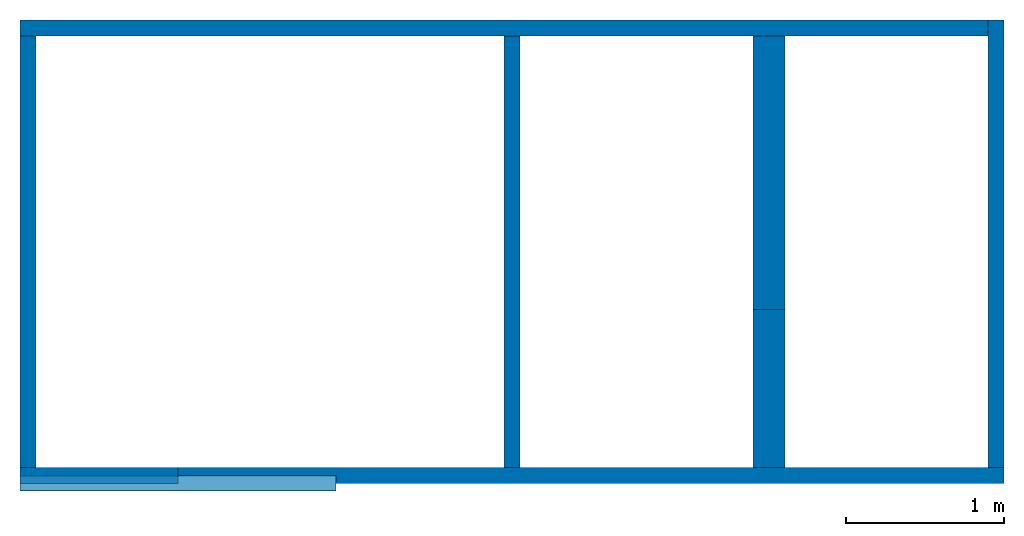
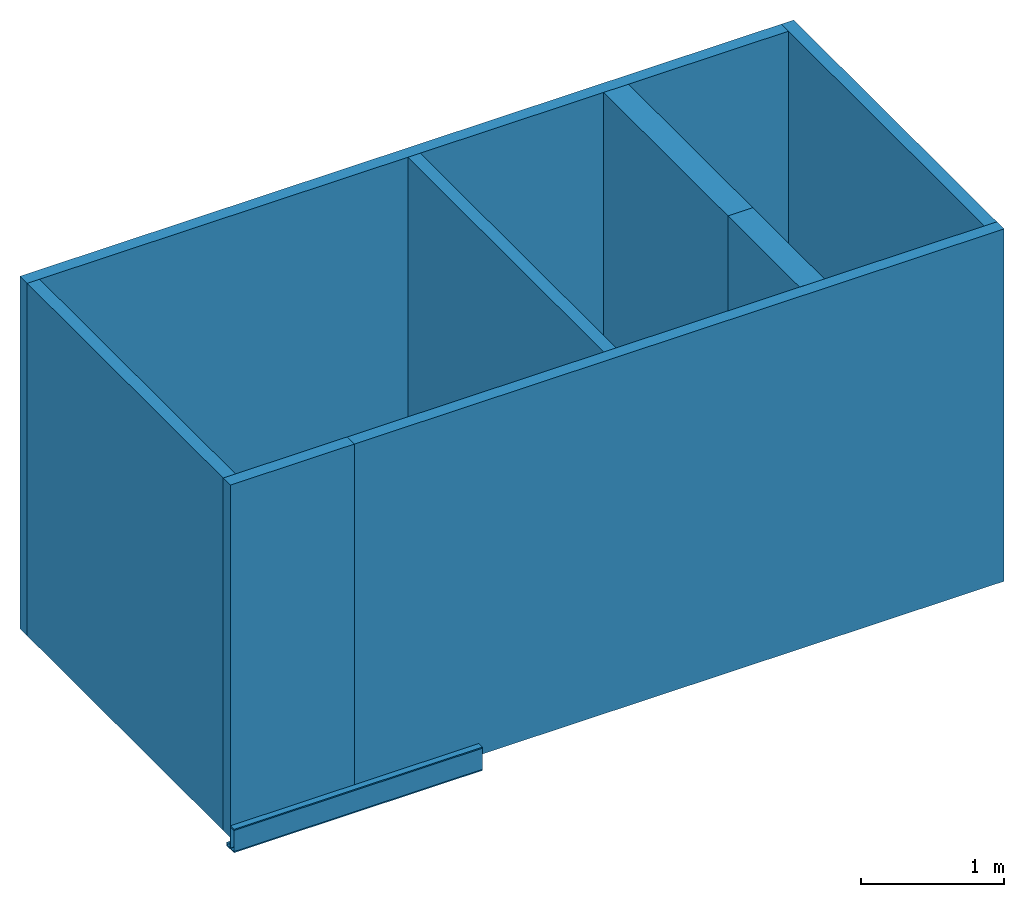
# One storey: 8 walls, 2 beams.
"""IFC4 building model written with IfcOpenShell, lengths in millimetres."""

from ifc_helpers import new_model, entity, si_unit, converted_unit, frame, origin_with_axes, place, context, subcontext, project, spatial, polyline, i_section, c_section, outline, extrude, material, layer, layer_set, layer_usage, material_profile, profile_set, profile_usage, type_object, element, save


model = new_model("IFC4")

# Units and contexts
model_context = context("Model", 3, precision=1e-05)
plan_context = context("Plan", 2, precision=1e-05)
body_context = subcontext(model_context, "Body", "Model", "MODEL_VIEW")
ifc_project = project(units=[si_unit("AREAUNIT", "SQUARE_METRE", prefix="MILLI"), si_unit("VOLUMEUNIT", "CUBIC_METRE", prefix="MILLI"), si_unit("LENGTHUNIT", "METRE", prefix="MILLI"), converted_unit("PLANEANGLEUNIT", "degree", entity("IfcReal", 0.0174532925199433), si_unit("PLANEANGLEUNIT", "RADIAN"), dimensions=[0, 0, 0, 0, 0, 0, 0])], contexts=[model_context, plan_context])

# Site, building, storey
site_placement = place(None, origin_with_axes())
site = spatial("IfcSite", under=ifc_project, at=site_placement)
building_placement = place(site_placement, origin_with_axes())
building = spatial("IfcBuilding", under=site, at=building_placement, Name="Building")
storey_placement = place(building_placement, origin_with_axes())
storey = spatial("IfcBuildingStorey", under=building, at=storey_placement, Name="Storey")

# Beams
ifc_material = material()
ifc_material_profile_1 = material_profile(ifc_material, i_section(OverallWidth=100.0, OverallDepth=200.0, WebThickness=5.0, FlangeThickness=10.0, FilletRadius=5.0))
ifc_profile_set_1 = profile_set([ifc_material_profile_1])
ifc_profile_usage_1 = profile_usage(ifc_profile_set_1)
beam_type_1 = type_object("IfcBeamType", Name="DEMO1", material=ifc_profile_set_1)
beam_1_placement = place(storey_placement, frame((0.0, 0.0, 0.0), z_axis=(1.0, 4.37113882867379e-08, -4.37113882867379e-08), x_axis=(-4.37113882867379e-08, 1.0, 0.0)))
element("IfcBeam", 1, at=beam_1_placement, inside=storey, type_object=beam_type_1, material=ifc_profile_usage_1, Name="Beam", context=body_context, shape_type="SweptSolid", body=[
    extrude(i_section(OverallWidth=100.0, OverallDepth=200.0, WebThickness=5.0, FlangeThickness=10.0, FilletRadius=5.0), None, (0.0, 0.0, 1.0), 2000.0),
])
ifc_material_profile_2 = material_profile(ifc_material, c_section(Depth=200.0, Width=100.0, WallThickness=1.5, Girth=30.0, InternalFilletRadius=5.0))
ifc_profile_set_2 = profile_set([ifc_material_profile_2])
ifc_profile_usage_2 = profile_usage(ifc_profile_set_2)
beam_type_2 = type_object("IfcBeamType", Name="DEMO2", material=ifc_profile_set_2)
beam_2_placement = place(storey_placement, frame((0.0, 0.0, 0.0), z_axis=(1.0, 4.37113882867379e-08, -4.37113882867379e-08), x_axis=(-4.37113882867379e-08, 1.0, 0.0)))
element("IfcBeam", 2, at=beam_2_placement, inside=storey, type_object=beam_type_2, material=ifc_profile_usage_2, Name="Beam", context=body_context, shape_type="SweptSolid", body=[
    extrude(c_section(Depth=200.0, Width=100.0, WallThickness=1.5, Girth=30.0, InternalFilletRadius=5.0), None, (0.0, 0.0, 1.0), 2000.0),
])

# Walls
ifc_layer_1 = layer(ifc_material, 100.0)
ifc_layer_set_1 = layer_set([ifc_layer_1])
ifc_layer_usage_1 = layer_usage(ifc_layer_set_1, "AXIS2", "POSITIVE", 0.0)
wall_type_1 = type_object("IfcWallType", Name="DEMO100", material=ifc_layer_set_1)
wall_1_placement = place(storey_placement, origin_with_axes())
element("IfcWall", 3, at=wall_1_placement, inside=storey, type_object=wall_type_1, material=ifc_layer_usage_1, Name="Wall", context=body_context, shape_type="SweptSolid", body=[
    extrude(outline(polyline([(-50.0000007450581, -500.0), (50.0000007450581, -500.0), (50.0000007450581, 500.0), (-50.0000007450581, 500.0), (-50.0000007450581, -500.0)])), frame((500.0, 50.0000007450581, 0.0), z_axis=(0.0, 0.0, -1.0), x_axis=(0.0, -1.0, 0.0)), (0.0, 0.0, -1.0), 3000.0),
])
ifc_layer_usage_2 = layer_usage(ifc_layer_set_1, "AXIS2", "POSITIVE", 0.0)
wall_2_placement = place(storey_placement, origin_with_axes())
element("IfcWall", 4, at=wall_2_placement, inside=storey, type_object=wall_type_1, material=ifc_layer_usage_2, Name="Wall", context=body_context, shape_type="SweptSolid", body=[
    extrude(outline(polyline([(-50.0000007450581, -3114.86148834229), (50.0000007450581, -3114.86148834229), (50.0000007450581, 3114.86148834229), (-50.0000007450581, 3114.86148834229), (-50.0000007450581, -3114.86148834229)])), frame((3114.86148834229, 50.0000007450581, 0.0), z_axis=(0.0, 0.0, -1.0), x_axis=(0.0, -1.0, 0.0)), (0.0, 0.0, -1.0), 3000.0),
])
ifc_layer_usage_3 = layer_usage(ifc_layer_set_1, "AXIS2", "POSITIVE", 0.0)
wall_3_placement = place(storey_placement, frame((6229.72297668457, 100.000023841858, 0.0), z_axis=(0.0, 0.0, 1.0), x_axis=(-4.37113882867379e-08, 1.0, 0.0)))
element("IfcWall", 5, at=wall_3_placement, inside=storey, type_object=wall_type_1, material=ifc_layer_usage_3, Name="Wall", context=body_context, shape_type="SweptSolid", body=[
    extrude(outline(polyline([(-49.999862909317, -1416.52250289917), (50.0000417232513, -1416.52250289917), (49.9999150633812, 1416.52250289917), (-50.0000864267349, 1416.52250289917), (-49.999862909317, -1416.52250289917)])), frame((1416.52250289917, 49.9999150633812, 0.0), z_axis=(0.0, 0.0, -1.0), x_axis=(0.0, -1.0, 0.0)), (0.0, 0.0, -1.0), 3000.0),
])
ifc_layer_usage_4 = layer_usage(ifc_layer_set_1, "AXIS2", "POSITIVE", 0.0)
wall_4_placement = place(storey_placement, frame((6129.723072052, 2933.04491043091, 0.0), z_axis=(0.0, 0.0, 1.0), x_axis=(-1.0, 1.50995802528087e-07, 0.0)))
element("IfcWall", 6, at=wall_4_placement, inside=storey, type_object=wall_type_1, material=ifc_layer_usage_4, Name="Wall", context=body_context, shape_type="SweptSolid", body=[
    extrude(outline(polyline([(-49.9998703598976, -3064.86129760742), (50.0002726912498, -3064.86129760742), (49.9997958540916, 3064.86129760742), (-50.0002056360245, 3064.86129760742), (-49.9998703598976, -3064.86129760742)])), frame((3064.86129760742, 49.9997958540916, 0.0), z_axis=(0.0, 0.0, -1.0), x_axis=(0.0, -1.0, 0.0)), (0.0, 0.0, -1.0), 3000.0),
])
ifc_layer_usage_5 = layer_usage(ifc_layer_set_1, "AXIS2", "POSITIVE", 0.0)
wall_5_placement = place(storey_placement, frame((0.000476837158203125, 2833.04619789124, 0.0), z_axis=(0.0, 0.0, 1.0), x_axis=(-1.62920684942947e-07, -1.0, 0.0)))
element("IfcWall", 7, at=wall_5_placement, inside=storey, type_object=wall_type_1, material=ifc_layer_usage_5, Name="Wall", context=body_context, shape_type="SweptSolid", body=[
    extrude(outline(polyline([(-50.000011920929, -1366.52302742004), (49.9999895691872, -1366.52302742004), (50.000011920929, 1366.52302742004), (-49.9999895691872, 1366.52302742004), (-50.000011920929, -1366.52302742004)])), frame((1366.52302742004, 50.000011920929, 0.0), z_axis=(0.0, 0.0, -1.0), x_axis=(0.0, -1.0, 0.0)), (0.0, 0.0, -1.0), 3000.0),
])
ifc_layer_usage_6 = layer_usage(ifc_layer_set_1, "AXIS2", "POSITIVE", 0.0)
wall_6_placement = place(storey_placement, frame((3064.86177444458, 2833.0454826355, 0.0), z_axis=(0.0, 0.0, 1.0), x_axis=(-1.62920684942947e-07, -1.0, 0.0)))
element("IfcWall", 8, at=wall_6_placement, inside=storey, type_object=wall_type_1, material=ifc_layer_usage_6, Name="Wall", context=body_context, shape_type="SweptSolid", body=[
    extrude(outline(polyline([(-49.9999821186066, -1366.52266979218), (50.0001609325409, -1366.52266979218), (49.9999076128006, 1366.52266979218), (-50.0000938773155, 1366.52266979218), (-49.9999821186066, -1366.52266979218)])), frame((1366.52266979218, 49.9999076128006, 0.0), z_axis=(0.0, 0.0, -1.0), x_axis=(0.0, -1.0, 0.0)), (0.0, 0.0, -1.0), 3000.0),
])
ifc_layer_2 = layer(ifc_material, 200.0)
ifc_layer_set_2 = layer_set([ifc_layer_2])
ifc_layer_usage_7 = layer_usage(ifc_layer_set_2, "AXIS2", "POSITIVE", 0.0)
wall_type_2 = type_object("IfcWallType", Name="DEMO200", material=ifc_layer_set_2)
wall_7_placement = place(storey_placement, frame((4841.92895889282, 100.000023841858, 0.0), z_axis=(0.0, 0.0, 1.0), x_axis=(-4.37113882867379e-08, 1.0, 0.0)))
element("IfcWall", 9, at=wall_7_placement, inside=storey, type_object=wall_type_2, material=ifc_layer_usage_7, Name="Wall", context=body_context, shape_type="SweptSolid", body=[
    extrude(outline(polyline([(-100.000001490116, -500.0), (100.000001490116, -500.0), (100.000001490116, 500.0), (-100.000001490116, 500.0), (-100.000001490116, -500.0)])), frame((500.0, 100.000001490116, 0.0), z_axis=(0.0, 0.0, -1.0), x_axis=(0.0, -1.0, 0.0)), (0.0, 0.0, -1.0), 3000.0),
])
ifc_layer_usage_8 = layer_usage(ifc_layer_set_2, "AXIS2", "POSITIVE", 0.0)
wall_8_placement = place(storey_placement, frame((4841.92895889282, 100.000023841858, 0.0), z_axis=(0.0, 0.0, 1.0), x_axis=(-4.37113882867379e-08, 1.0, 0.0)))
element("IfcWall", 10, at=wall_8_placement, inside=storey, type_object=wall_type_2, material=ifc_layer_usage_8, Name="Wall", context=body_context, shape_type="SweptSolid", body=[
    extrude(outline(polyline([(-100.00142455101, -1366.52266979218), (99.9983847141266, -1366.52266979218), (100.001521408558, 1366.52266979218), (-99.9984815716743, 1366.52290821075), (-100.00142455101, -1366.52266979218)])), frame((1366.52278900146, 99.9998897314072, 0.0), z_axis=(0.0, 0.0, -1.0), x_axis=(-1.19209403237619e-06, -1.0, 0.0)), (8.84483597474173e-10, -7.105427357601e-15, -1.0), 3000.0),
])

save(model, "model.ifc")
